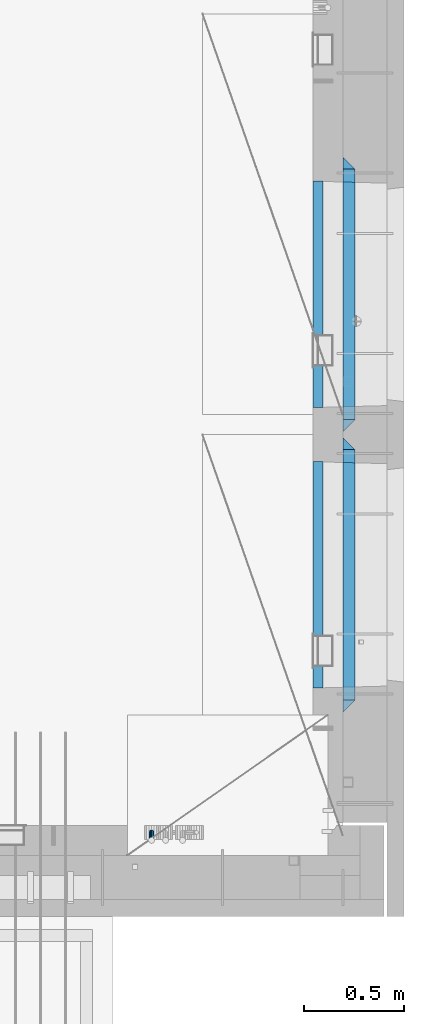
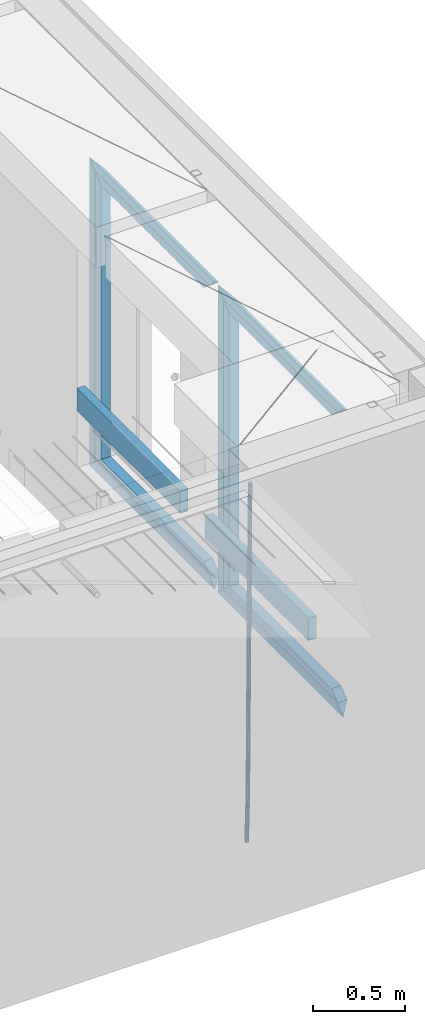
# One storey, part 124 of 334: 15 beams, 2 elements without a shape of their own.
"""IFC2X3 building model written with IfcOpenShell, lengths in millimetres."""

from ifc_helpers import new_model, si_unit, frame, origin_with_axes, place, context, subcontext, project, spatial, faceted_brep, material, type_object, element, aggregate, save


model = new_model("IFC2X3")

# Units and contexts
model_context = context("Model", 3, precision=1e-05, world=origin_with_axes())
body_context = subcontext(model_context, "Body", "Model", "MODEL_VIEW")
ifc_project = project(units=[si_unit("LENGTHUNIT", "METRE", prefix="MILLI"), si_unit("AREAUNIT", "SQUARE_METRE"), si_unit("VOLUMEUNIT", "CUBIC_METRE"), si_unit("MASSUNIT", "GRAM", prefix="KILO"), si_unit("TIMEUNIT", "SECOND"), si_unit("PLANEANGLEUNIT", "RADIAN"), si_unit("SOLIDANGLEUNIT", "STERADIAN"), si_unit("THERMODYNAMICTEMPERATUREUNIT", "DEGREE_CELSIUS"), si_unit("LUMINOUSINTENSITYUNIT", "LUMEN")], contexts=[model_context])

# Site, building, storey
site_placement = place(None, origin_with_axes())
site = spatial("IfcSite", under=ifc_project, at=site_placement, CompositionType="ELEMENT")
building_placement = place(site_placement, origin_with_axes())
building = spatial("IfcBuilding", under=site, at=building_placement, CompositionType="ELEMENT")
storey_placement = place(building_placement, origin_with_axes())
storey = spatial("IfcBuildingStorey", under=building, at=storey_placement, Name="3", CompositionType="ELEMENT", Elevation=0.0)

# Assembly, beam
assembly_1_placement = place(storey_placement, origin_with_axes())
assembly_1 = element("IfcElementAssembly", 1, at=assembly_1_placement, inside=storey, AssemblyPlace="NOTDEFINED", PredefinedType="REINFORCEMENT_UNIT")
ifc_material_1 = material()
beam_type_1 = type_object("IfcBeamType", Name="D25", PredefinedType="NOTDEFINED")
beam_1_placement = place(assembly_1_placement, frame((34104.9999999961, 7965.00000227913, 87990.0), z_axis=(0.00020576299992186, -0.999642804629538, -0.0267249099901004), x_axis=(-4.30000201928125e-08, -0.0267249099948059, 0.999642825806181)))
beam_1 = element("IfcBeam", 2, at=beam_1_placement, type_object=beam_type_1, material=ifc_material_1, Name="JM25", ObjectType="D25", context=body_context, shape_type="Brep", body=[
    faceted_brep([(-7.41420080885291e-08, -12.5, -3.63797880709171e-12), (-6.42030499875546e-08, -10.8253175473074, -6.25000000000364), (60.4103898235917, -10.8253175318459, -6.2499999938409), (60.4103898269532, -12.4999999845422, 6.16273609921336e-09), (-3.70782800018787e-08, -6.25000000000364, -10.8253175473074), (60.4103898202884, -6.24999998454587, -10.8253175411446), (-1.45519152283669e-11, -3.63797880709171e-12, -12.5), (60.4103898179019, 1.54577719513327e-08, -12.4999999938373), (3.70637280866504e-08, 6.25, -10.8253175473074), (60.410389817087, 6.25000001545777, -10.825317541141), (6.42030499875546e-08, 10.8253175473001, -6.25000000000364), (60.410389818062, 10.8253175627578, -6.24999999383726), (7.41420080885291e-08, 12.4999999999927, 0.0), (60.4103898205503, 12.5000000154541, 6.16273609921336e-09), (6.42176019027829e-08, 10.8253175473001, 6.24999999999636), (60.4103898238973, 10.8253175627651, 6.2500000061591), (3.70928319171071e-08, 6.24999999999636, 10.8253175473037), (60.4103898272151, 6.25000001546141, 10.8253175534664), (1.45519152283669e-11, -3.63797880709171e-12, 12.4999999999964), (60.4103898296162, 1.54541339725256e-08, 12.5000000061591), (-3.7049176171422e-08, -6.25000000000364, 10.8253175473001), (60.4103898304165, -6.24999998454587, 10.8253175534701), (-6.41884980723262e-08, -10.8253175473074, 6.25), (60.4103898294561, -10.8253175318459, 6.25000000616637), (61.0324985728803, -10.8253175316895, -6.24999999377542), (60.991802792938, -12.4999999843931, 6.22458173893392e-09), (61.0622854283865, -6.24999998437852, -10.8253175410755), (61.0731819955545, 1.5628756955266e-08, -12.4999999937718), (61.0622685480339, 6.25000001562512, -10.8253175410791), (61.032469335245, 10.8253175629216, -6.24999999377178), (60.9917690322181, 12.5000000156033, 6.22458173893392e-09), (60.9510732522613, 10.8253175629034, 6.25000000621731), (60.9212863967696, 6.25000001558874, 10.8253175535247), (60.9103898296162, 1.55814632307738e-08, 12.5000000062137), (60.9213032771368, -6.24999998441126, 10.8253175535174), (60.9511024898966, -10.8253175317113, 6.25000000621731), (61.6545545670233, -10.8253158516927, -6.24189838219536), (61.573166454793, -12.499998414296, 0.00757164385504439), (61.7141257553885, -6.24999822394238, -10.8168280205282), (61.7359179680789, 1.80548886419274e-06, -12.491368569139), (61.7140919992817, 6.25000177601396, -10.8168282403167), (61.6544960997562, 10.8253192428383, -6.2418987628771), (61.5730989426083, 12.5000015856094, 0.0075712042817031), (61.4917108303925, 10.8253190230062, 6.25704123032847), (61.4321396420273, 6.25000139525582, 10.8319708686649), (61.4103474293224, 1.36582457344048e-06, 12.5065114172721), (61.4321733981196, -6.24999860470052, 10.8319710884571), (61.4917692976451, -10.8253160715249, 6.25704161101385), (176.524302641745, -10.8250056210964, -4.74584321979273), (176.442914529529, -12.4996881836996, 1.50362680625403), (176.583873830095, -6.24968799334965, -9.3207728581292), (176.605666042786, 0.000312036081595579, -10.9953134067364), (176.583840074018, 6.25031200660669, -9.32077307791769), (176.524244174492, 10.8256294734347, -4.74584360047811), (176.44284701733, 12.5003118162058, 1.50362636668069), (176.361458905099, 10.8256292535989, 7.75309639272746), (176.301887716749, 6.25031162585219, 12.3280260310676), (176.280095504058, 0.000311596420942806, 14.0025665796711), (176.301921472827, -6.24968837410415, 12.3280262508561), (176.361517372367, -10.8250058409321, 7.75309677341284), (177.085397012124, -10.8250041057399, -4.73853556792164), (176.983633547483, -12.4996867233749, 1.51066909103247), (177.159881729676, -6.24968643771717, -9.31327097355097), (177.187129580227, 0.000313606451527448, -10.987740468332), (177.159839524218, 6.25031356221734, -9.31327130338468), (177.085323910098, 10.8256309887511, -4.73853613920801), (176.983549136537, 12.5003132764905, 1.51066843136869), (176.881785671867, 10.8256306588555, 7.7598730903228), (176.80730095433, 6.25031299082912, 12.3346084959521), (176.780053103794, 0.000312946667690994, 14.0090779907332), (176.807343159802, -6.2496870091054, 12.3346088257895), (176.881858773908, -10.8250044356355, 7.7598736616128), (177.646431799818, -10.8250018318176, -4.72756919822132), (177.524295146417, -12.4996845320202, 1.52123723245313), (177.735828462886, -6.24968410334986, -9.30201312475765), (177.768531371941, 0.00031596292683389, -10.9763759912421), (177.735777808921, 6.25031589654827, -9.30201361973741), (177.646344064575, 10.8256332626152, -4.72757005553649), (177.524193838486, 12.5003154677688, 1.52123624250817), (177.402057185071, 10.8256327675663, 7.77004267317898), (177.312660521988, 6.2503150390985, 12.3444865997226), (177.279957612933, 0.00031497282179771, 14.0188494661961), (177.312711175953, -6.24968496079964, 12.3444870946951), (177.402144920314, -10.8250023268702, 7.77004353049415), (299.377443161706, -10.8245084454466, -2.34813158632096), (299.255306508276, -12.4991911456491, 3.90067484435349), (299.466839824803, -6.24919071697514, -6.92257551286093), (299.499542733873, 0.0008093492979242, -8.59693837933446), (299.466789170867, 6.250809282923, -6.92257600783341), (299.377355426492, 10.8261266489935, -2.34813244364341), (299.255205200388, 12.5008088541435, 3.90067385440125), (299.133068546944, 10.826126153941, 10.1494802850757), (299.043671883861, 6.25080842546959, 14.7239242116229), (299.010968974762, 0.000808359200163977, 16.3982870780892), (299.043722537797, -6.24919157442127, 14.7239247065918), (299.133156282158, -10.8245089404954, 10.1494811423981), (299.98561436501, -10.8245059804758, -2.33624385599614), (299.97179243555, -12.4991882411778, 3.91467976726199), (299.995742293278, -6.24918857328521, -6.91223722345239), (299.999447243041, 0.000811375455668895, -8.58716690387519), (299.995736475976, 6.25081142679483, -6.91223684201032), (299.985604289133, 10.8261291142808, -2.33624319533556), (299.971750386685, 12.5008117588586, 3.91467993563856), (299.957928457196, 10.8261294971744, 10.1656035610831), (299.947800528913, 6.25081208998381, 14.7415969285394), (299.944095579151, 0.00081214124293183, 16.4165266089549), (299.947806346216, -6.24918791008895, 14.7415965471009), (299.957938533058, -10.8245055975785, 10.1656029004225), (300.593832239858, -10.8245078794353, -2.34543881707941), (300.688302931099, -12.4991904788549, 3.90384712594823), (300.524685350189, -6.24919022474205, -6.92023371784308), (300.499390115292, 0.000809814544481924, -8.59472497713432), (300.524724372954, 6.25080977519247, -6.92023401429469), (300.593899829313, 10.8261272150703, -2.34543933054374), (300.688380976673, 12.5008095210287, 3.90384653304136), (300.782851667915, 10.8261269216127, 10.1531324760799), (300.851998557599, 6.25080926691589, 14.7279273768363), (300.877293792495, 0.000809227632998955, 16.4024186361276), (300.851959534804, -6.24919073302226, 14.7279276732806), (300.782784078474, -10.8245081728965, 10.153132989537), (2293.32930409742, -10.8307295605009, -32.4713622331001), (2293.42377478865, -12.5054121599169, -26.2220762900724), (2293.26015720774, -6.2554119058077, -37.0461571338565), (2293.23486197284, -0.00541186651753378, -38.7206483931477), (2293.26019623051, 6.24458809413409, -37.0461574303008), (2293.32937168686, 10.8199055340046, -32.4713627465644), (2293.42385283421, 12.4945878399631, -26.2220768829684), (2293.51832352545, 10.8199052405434, -19.972790939948), (2293.58747041514, 6.24458758585388, -15.3979960391844), (2293.61276565003, -0.00541245343265473, -13.7235047798931), (2293.58743139236, -6.25541241408428, -15.3979957427327), (2293.51825593603, -10.8307298539585, -19.9727904264691), (2294.0420846676, -10.8307317859326, -32.4821379598216), (2294.03681932652, -12.5054140739521, -26.2313442200393), (2294.06778164886, -6.2554144273563, -37.0583666982457), (2294.10702478497, -0.00541458957013674, -38.7338336404937), (2294.14929890928, 6.24458531819619, -37.0595987724118), (2294.18327670435, 10.8199028679592, -32.4842719748667), (2294.1998538474, 12.4945854171456, -26.2338083683717), (2294.19458850632, 10.819903129126, -19.9830146285858), (2294.16889152506, 6.24458577054975, -15.4067858901581), (2294.12964838895, -0.0054140672327776, -13.7313189479173), (2294.08737426462, -6.2554139749991, -15.4055538159919), (2294.05339646956, -10.8307315247621, -19.9808806135297), (2294.75482297382, -10.84002603931, -32.4726521173216), (2294.64982751427, -12.513407826169, -26.2231856868602), (2294.87535820232, -6.26594539088183, -37.0476186524102), (2294.97913588268, -0.0167870967634371, -38.7222267036377), (2295.0383488692, 6.23299192477134, -37.0477663960555), (2295.03713108998, 10.8087684320271, -32.4729080168181), (2294.97580884799, 12.4844668051373, -26.2234811741473), (2294.87081338844, 10.8110850182784, -19.9740147436787), (2294.7502781599, 6.23700436985018, -15.3990482086047), (2294.64650047956, -0.0121539242718427, -13.7244401573698), (2294.58728749304, -6.26193294580662, -15.3989004649666), (2294.58850527227, -10.8377094530588, -19.9737588441894), (2316.44667268227, -11.1228921988077, -32.1839550346631), (2316.34167722271, -12.7962739856739, -25.9344886042054), (2316.56720791078, -6.54881155039038, -36.7589215697517), (2316.67098559113, -0.299653256264719, -38.4335296209792), (2316.73019857766, 5.95012576527006, -36.759069313397), (2316.72898079845, 10.5259022725259, -32.1842109341669), (2316.66765855643, 12.2016006456361, -25.9347840914961), (2316.56266309689, 10.5282188587698, -19.6853176610275), (2316.44212786836, 5.95413821035254, -15.1103511259389), (2316.33835018802, -0.295020083769487, -13.4357430747186), (2316.27913720149, -6.54479910530426, -15.1102033823008), (2316.28035498071, -11.1205756125637, -19.685061761531), (2317.13234804722, -11.1318335458927, -32.1748293731798), (2317.04181141085, -12.8054038787741, -25.9251705100723), (2317.2154741603, -6.5572650749491, -36.7502937866229), (2317.26891617525, -0.307450393454928, -38.4255717558117), (2317.27835434731, 5.94297770185585, -36.7517739018112), (2317.24125972588, 10.5192220504723, -32.1773930078925), (2317.16757178486, 12.1950816748285, -25.9281307404563), (2317.0770351485, 10.5215113419545, -19.6784718773561), (2316.99390903539, 5.94694287101083, -15.1030074639057), (2316.94046702047, -0.302871810494253, -13.4277294947169), (2316.9310288484, -6.55329990579412, -15.1015273487101), (2316.96812346982, -11.1295442544142, -19.6759082426288), (2317.81808136747, -11.1298054502913, -32.1659056455355), (2317.74200467508, -12.803315894289, -25.9160547315114), (2317.86379538118, -6.55536082026447, -36.7418676070083), (2317.8668976831, -0.305700748642266, -38.417815303761), (2317.82655701396, 5.94458339541234, -36.7446799039099), (2317.75358262347, 10.5207330230332, -32.1707766866384), (2317.66752794063, 12.1965725370646, -25.9216793252963), (2317.59145124823, 10.5230620930706, -19.6718284112721), (2317.54573723453, 5.94861746304377, -15.0958664497994), (2317.54263493262, -0.301042608574789, -13.4199187530394), (2317.58297560175, -6.55132675263303, -15.0930541529051), (2317.65594999224, -11.1274763802539, -19.6669573701693), (2417.81884292323, -10.831603083323, -30.8687911350135), (2417.74276623082, -12.505113527317, -24.618940220982), (2417.86455693691, -6.25715845329614, -35.4447530964935), (2417.86765923884, -0.00749838167394046, -37.1207007932499), (2417.82731856969, 6.24278576237703, -35.4475653933878), (2417.75434417921, 10.8189353900088, -30.8736621761236), (2417.66828949639, 12.494774904033, -24.6245648147851), (2417.59221280397, 10.8212644600353, -18.3747139007501), (2417.54649879028, 6.2468198300121, -13.79875193927), (2417.54339648837, -0.00284024161010166, -12.1228042425173), (2417.5837371575, -6.25312438566107, -13.795939642383), (2417.65671154798, -10.8292740132893, -18.3698428596399)], [[[0, 1, 2, 3]], [[1, 4, 5, 2]], [[4, 6, 7, 5]], [[6, 8, 9, 7]], [[8, 10, 11, 9]], [[10, 12, 13, 11]], [[12, 14, 15, 13]], [[14, 16, 17, 15]], [[16, 18, 19, 17]], [[18, 20, 21, 19]], [[20, 22, 23, 21]], [[22, 0, 3, 23]], [[22, 20, 18, 16, 14, 12, 10, 8, 6, 4, 1, 0]], [[3, 2, 24, 25]], [[2, 5, 26, 24]], [[5, 7, 27, 26]], [[7, 9, 28, 27]], [[9, 11, 29, 28]], [[11, 13, 30, 29]], [[13, 15, 31, 30]], [[15, 17, 32, 31]], [[17, 19, 33, 32]], [[19, 21, 34, 33]], [[21, 23, 35, 34]], [[23, 3, 25, 35]], [[25, 24, 36, 37]], [[24, 26, 38, 36]], [[26, 27, 39, 38]], [[27, 28, 40, 39]], [[28, 29, 41, 40]], [[29, 30, 42, 41]], [[30, 31, 43, 42]], [[31, 32, 44, 43]], [[32, 33, 45, 44]], [[33, 34, 46, 45]], [[34, 35, 47, 46]], [[35, 25, 37, 47]], [[37, 36, 48, 49]], [[36, 38, 50, 48]], [[38, 39, 51, 50]], [[39, 40, 52, 51]], [[40, 41, 53, 52]], [[41, 42, 54, 53]], [[42, 43, 55, 54]], [[43, 44, 56, 55]], [[44, 45, 57, 56]], [[45, 46, 58, 57]], [[46, 47, 59, 58]], [[47, 37, 49, 59]], [[49, 48, 60, 61]], [[48, 50, 62, 60]], [[50, 51, 63, 62]], [[51, 52, 64, 63]], [[52, 53, 65, 64]], [[53, 54, 66, 65]], [[54, 55, 67, 66]], [[55, 56, 68, 67]], [[56, 57, 69, 68]], [[57, 58, 70, 69]], [[58, 59, 71, 70]], [[59, 49, 61, 71]], [[61, 60, 72, 73]], [[60, 62, 74, 72]], [[62, 63, 75, 74]], [[63, 64, 76, 75]], [[64, 65, 77, 76]], [[65, 66, 78, 77]], [[66, 67, 79, 78]], [[67, 68, 80, 79]], [[68, 69, 81, 80]], [[69, 70, 82, 81]], [[70, 71, 83, 82]], [[71, 61, 73, 83]], [[73, 72, 84, 85]], [[72, 74, 86, 84]], [[74, 75, 87, 86]], [[75, 76, 88, 87]], [[76, 77, 89, 88]], [[77, 78, 90, 89]], [[78, 79, 91, 90]], [[79, 80, 92, 91]], [[80, 81, 93, 92]], [[81, 82, 94, 93]], [[82, 83, 95, 94]], [[83, 73, 85, 95]], [[85, 84, 96, 97]], [[84, 86, 98, 96]], [[86, 87, 99, 98]], [[87, 88, 100, 99]], [[88, 89, 101, 100]], [[89, 90, 102, 101]], [[90, 91, 103, 102]], [[91, 92, 104, 103]], [[92, 93, 105, 104]], [[93, 94, 106, 105]], [[94, 95, 107, 106]], [[95, 85, 97, 107]], [[97, 96, 108, 109]], [[96, 98, 110, 108]], [[98, 99, 111, 110]], [[99, 100, 112, 111]], [[100, 101, 113, 112]], [[101, 102, 114, 113]], [[102, 103, 115, 114]], [[103, 104, 116, 115]], [[104, 105, 117, 116]], [[105, 106, 118, 117]], [[106, 107, 119, 118]], [[107, 97, 109, 119]], [[109, 108, 120, 121]], [[108, 110, 122, 120]], [[110, 111, 123, 122]], [[111, 112, 124, 123]], [[112, 113, 125, 124]], [[113, 114, 126, 125]], [[114, 115, 127, 126]], [[115, 116, 128, 127]], [[116, 117, 129, 128]], [[117, 118, 130, 129]], [[118, 119, 131, 130]], [[119, 109, 121, 131]], [[121, 120, 132, 133]], [[120, 122, 134, 132]], [[122, 123, 135, 134]], [[123, 124, 136, 135]], [[124, 125, 137, 136]], [[125, 126, 138, 137]], [[126, 127, 139, 138]], [[127, 128, 140, 139]], [[128, 129, 141, 140]], [[129, 130, 142, 141]], [[130, 131, 143, 142]], [[131, 121, 133, 143]], [[133, 132, 144, 145]], [[132, 134, 146, 144]], [[134, 135, 147, 146]], [[135, 136, 148, 147]], [[136, 137, 149, 148]], [[137, 138, 150, 149]], [[138, 139, 151, 150]], [[139, 140, 152, 151]], [[140, 141, 153, 152]], [[141, 142, 154, 153]], [[142, 143, 155, 154]], [[143, 133, 145, 155]], [[145, 144, 156, 157]], [[144, 146, 158, 156]], [[146, 147, 159, 158]], [[147, 148, 160, 159]], [[148, 149, 161, 160]], [[149, 150, 162, 161]], [[150, 151, 163, 162]], [[151, 152, 164, 163]], [[152, 153, 165, 164]], [[153, 154, 166, 165]], [[154, 155, 167, 166]], [[155, 145, 157, 167]], [[157, 156, 168, 169]], [[156, 158, 170, 168]], [[158, 159, 171, 170]], [[159, 160, 172, 171]], [[160, 161, 173, 172]], [[161, 162, 174, 173]], [[162, 163, 175, 174]], [[163, 164, 176, 175]], [[164, 165, 177, 176]], [[165, 166, 178, 177]], [[166, 167, 179, 178]], [[167, 157, 169, 179]], [[169, 168, 180, 181]], [[168, 170, 182, 180]], [[170, 171, 183, 182]], [[171, 172, 184, 183]], [[172, 173, 185, 184]], [[173, 174, 186, 185]], [[174, 175, 187, 186]], [[175, 176, 188, 187]], [[176, 177, 189, 188]], [[177, 178, 190, 189]], [[178, 179, 191, 190]], [[179, 169, 181, 191]], [[181, 180, 192, 193]], [[180, 182, 194, 192]], [[182, 183, 195, 194]], [[183, 184, 196, 195]], [[184, 185, 197, 196]], [[185, 186, 198, 197]], [[186, 187, 199, 198]], [[187, 188, 200, 199]], [[188, 189, 201, 200]], [[189, 190, 202, 201]], [[190, 191, 203, 202]], [[191, 181, 193, 203]], [[194, 195, 196, 197, 198, 199, 200, 201, 202, 203, 193, 192]]]),
])
aggregate(assembly_1, [beam_1])

# Assembly, beams
assembly_2_placement = place(storey_placement, origin_with_axes())
assembly_2 = element("IfcElementAssembly", 3, at=assembly_2_placement, inside=storey, AssemblyPlace="NOTDEFINED", PredefinedType="REINFORCEMENT_UNIT")
ifc_material_2 = material(Name="TIMBER/T24")
beam_type_2 = type_object("IfcBeamType", PredefinedType="NOTDEFINED")
beam_2_placement = place(assembly_2_placement, frame((34935.0002758707, 8685.00118845241, 88685.0), z_axis=(0.0, 0.0, 1.0), x_axis=(0.0, 1.0, 0.0)))
beam_2 = element("IfcBeam", 4, at=beam_2_placement, type_object=beam_type_2, material=ifc_material_2, context=body_context, shape_type="Brep", body=[
    faceted_brep([(-3.63797880709171e-12, 24.9999999999964, -75.0), (-3.63797880709171e-12, 24.9999999999964, 75.0), (1130.0, 25.0, 75.0), (1130.0, 25.0, -75.0), (0.0, -25.0000000000073, 75.0), (1130.0, -25.0, 75.0), (0.0, -25.0000000000073, -75.0), (1130.0, -25.0, -75.0)], [[[0, 1, 2, 3]], [[1, 4, 5, 2]], [[4, 6, 7, 5]], [[6, 0, 3, 7]], [[5, 7, 3, 2]], [[6, 4, 1, 0]]]),
])
beam_3_placement = place(assembly_2_placement, frame((34935.0002758707, 10085.0011884524, 88685.0), z_axis=(0.0, 0.0, 1.0), x_axis=(0.0, 1.0, 0.0)))
beam_3 = element("IfcBeam", 5, at=beam_3_placement, type_object=beam_type_2, material=ifc_material_2, context=body_context, shape_type="Brep", body=[
    faceted_brep([(-3.63797880709171e-12, 24.9999999999964, -75.0), (-3.63797880709171e-12, 24.9999999999964, 75.0), (1130.0, 25.0, 75.0), (1130.0, 25.0, -75.0), (0.0, -25.0000000000073, 75.0), (1130.0, -25.0, 75.0), (0.0, -25.0000000000073, -75.0), (1130.0, -25.0, -75.0)], [[[0, 1, 2, 3]], [[1, 4, 5, 2]], [[4, 6, 7, 5]], [[6, 0, 3, 7]], [[5, 7, 3, 2]], [[6, 4, 1, 0]]]),
])
ifc_material_3 = material(Name="CONCRETE/C25/30")
beam_type_3 = type_object("IfcBeamType", PredefinedType="NOTDEFINED")
beam_4_placement = place(assembly_2_placement, frame((35090.0, 8565.0001381367, 90145.0), z_axis=(0.0, 0.0, -1.0), x_axis=(0.0, 1.0, 0.0)))
beam_4 = element("IfcBeam", 6, at=beam_4_placement, type_object=beam_type_3, material=ifc_material_3, Name="SK", context=body_context, shape_type="Brep", body=[
    faceted_brep([(60.0000000000073, 30.0, 30.0), (0.0, -30.0, -30.0), (60.0000000000073, -30.0, 30.0), (1309.99990463256, 30.0, 30.0), (1369.99990463257, -30.0, -30.0), (1309.99990463256, -30.0, 30.0)], [[[0, 1, 2]], [[1, 0, 3, 4]], [[2, 1, 4, 5]], [[0, 2, 5, 3]], [[4, 3, 5]]]),
])
beam_5_placement = place(assembly_2_placement, frame((35090.0, 8625.0001381367, 90085.0), z_axis=(0.0, 0.0, -1.0), x_axis=(0.0, 1.0, 0.0)))
beam_5 = element("IfcBeam", 7, at=beam_5_placement, type_object=beam_type_3, material=ifc_material_3, Name="SK", context=body_context, shape_type="Brep", body=[
    faceted_brep([(65.6755803082433, 30.0, 25.6756756756804), (64.0539586866216, -30.0, 24.0540540540533), (1185.94585057852, -30.0, 24.0540540540533), (1184.32422895689, 30.0, 25.6756756756804), (65.6755803082433, 30.0, 26.2933545375708), (64.0539586866216, -30.0, 24.9033931479062), (0.0, -30.0, -30.0), (0.0, 30.0, -30.0), (1249.99990463257, 30.0, -30.0), (1249.99990463257, -30.0, -30.0), (1185.94585057852, -30.0, 24.9034748914273), (1184.32422895689, 30.0, 26.293436281092)], [[[0, 1, 2, 3]], [[1, 0, 4, 5]], [[6, 5, 4, 7]], [[6, 7, 8, 9]], [[2, 1, 5, 6, 9, 10]], [[3, 2, 10, 11]], [[7, 4, 0, 3, 11, 8]], [[10, 9, 8, 11]]]),
])
beam_6_placement = place(assembly_2_placement, frame((35090.0, 9905.00004276927, 90175.0), z_axis=(0.0, -1.0, 0.0), x_axis=(0.0, 0.0, -1.0)))
beam_6 = element("IfcBeam", 8, at=beam_6_placement, type_object=beam_type_3, material=ifc_material_3, Name="SK", context=body_context, shape_type="Brep", body=[
    faceted_brep([(60.0000000000073, 30.0, 30.0), (0.0, -30.0, -30.0), (60.0000000000073, -30.0, 30.0), (1995.0, 30.0, 30.0), (2055.0, -30.0, -30.0), (1995.0, -30.0, 30.0)], [[[0, 1, 2]], [[3, 4, 1, 0]], [[4, 5, 2, 1]], [[5, 3, 0, 2]], [[5, 4, 3]]]),
])
beam_7_placement = place(assembly_2_placement, frame((35090.0, 9875.00004276927, 88210.0), z_axis=(0.0, 0.0, 1.0), x_axis=(0.0, -1.0, 0.0)))
beam_7 = element("IfcBeam", 9, at=beam_7_placement, type_object=beam_type_3, material=ifc_material_3, Name="SK", context=body_context, shape_type="Brep", body=[
    faceted_brep([(1185.94594588314, -29.9999988381387, 24.0540541168593), (1184.32432432432, 29.9999988381387, 25.6756756756804), (65.6756756756768, 30.0, 25.6756756756804), (64.0540540540533, -30.0, 24.0540540540533), (1185.94594594595, -30.0, 24.9033931479207), (1184.32432432433, 30.0, 26.2933545375854), (1249.99990463257, -30.0, -30.0), (1249.99990463257, 30.0, -30.0), (0.0, 30.0, -30.0), (65.6756756756768, 30.0, 26.293436281092), (64.0540540540533, -30.0, 24.9034748914419), (0.0, -30.0, -30.0)], [[[0, 1, 2, 3]], [[1, 0, 4, 5]], [[6, 7, 5, 4]], [[2, 1, 5, 7, 8, 9]], [[3, 2, 9, 10]], [[6, 4, 0, 3, 10, 11]], [[11, 8, 7, 6]], [[11, 10, 9, 8]]]),
])
beam_8_placement = place(assembly_2_placement, frame((35090.0, 9935.00004276927, 88150.0), z_axis=(0.0, 0.0, 1.0), x_axis=(0.0, -1.0, 0.0)))
beam_8 = element("IfcBeam", 10, at=beam_8_placement, type_object=beam_type_3, material=ifc_material_3, Name="SK", context=body_context, shape_type="Brep", body=[
    faceted_brep([(1369.99990463257, -30.0, -30.0), (1309.99990463256, 30.0, 30.0), (1309.99990463256, -30.0, 30.0), (60.0000000000073, 30.0, 30.0), (60.0000000000073, -30.0, 30.0), (0.0, -30.0, -30.0)], [[[0, 1, 2]], [[3, 4, 2, 1]], [[4, 5, 0, 2]], [[5, 3, 1, 0]], [[3, 5, 4]]]),
])
beam_9_placement = place(assembly_2_placement, frame((35090.0, 9965.00023350414, 90145.0), z_axis=(0.0, 0.0, -1.0), x_axis=(0.0, 1.0, 0.0)))
beam_9 = element("IfcBeam", 11, at=beam_9_placement, type_object=beam_type_3, material=ifc_material_3, Name="SK", context=body_context, shape_type="Brep", body=[
    faceted_brep([(60.0000000000073, 30.0, 30.0), (0.0, -30.0, -30.0), (60.0000000000073, -30.0, 30.0), (1309.99942779541, 30.0, 30.0), (1369.99942779541, -30.0, -30.0), (1309.99942779541, -30.0, 30.0)], [[[0, 1, 2]], [[1, 0, 3, 4]], [[2, 1, 4, 5]], [[0, 2, 5, 3]], [[4, 3, 5]]]),
])
beam_10_placement = place(assembly_2_placement, frame((35090.0, 10025.0002335041, 90085.0), z_axis=(0.0, 0.0, -1.0), x_axis=(0.0, 1.0, 0.0)))
beam_10 = element("IfcBeam", 12, at=beam_10_placement, type_object=beam_type_3, material=ifc_material_3, Name="SK", context=body_context, shape_type="Brep", body=[
    faceted_brep([(65.6751034710851, 30.0, 25.6756756756804), (64.0534818494634, -30.0, 24.0540540540533), (1185.94537374136, -30.0, 24.0540540540533), (1184.32375211974, 30.0, 25.6756756756804), (65.6751034710851, 30.0, 26.2929458199942), (64.0534818494634, -30.0, 24.9029844303586), (0.0, -30.0, -30.0), (0.0, 30.0, -30.0), (1249.99942779541, 30.0, -30.0), (1249.99942779541, -30.0, -30.0), (1185.94537374136, -30.0, 24.9034748914273), (1184.32375211974, 30.0, 26.293436281092)], [[[0, 1, 2, 3]], [[1, 0, 4, 5]], [[6, 5, 4, 7]], [[6, 7, 8, 9]], [[2, 1, 5, 6, 9, 10]], [[3, 2, 10, 11]], [[7, 4, 0, 3, 11, 8]], [[10, 9, 8, 11]]]),
])
beam_11_placement = place(assembly_2_placement, frame((35090.0, 11304.9996612995, 90175.0), z_axis=(0.0, -1.0, 0.0), x_axis=(0.0, 0.0, -1.0)))
beam_11 = element("IfcBeam", 13, at=beam_11_placement, type_object=beam_type_3, material=ifc_material_3, Name="SK", context=body_context, shape_type="Brep", body=[
    faceted_brep([(60.0000000000073, 30.0, 30.0), (0.0, -30.0, -30.0), (60.0000000000073, -30.0, 30.0), (1995.0, 30.0, 30.0), (2055.0, -30.0, -30.0), (1995.0, -30.0, 30.0)], [[[0, 1, 2]], [[3, 4, 1, 0]], [[4, 5, 2, 1]], [[5, 3, 0, 2]], [[5, 4, 3]]]),
])
beam_12_placement = place(assembly_2_placement, frame((35090.0, 11274.9996612995, 88210.0), z_axis=(0.0, 0.0, 1.0), x_axis=(0.0, -1.0, 0.0)))
beam_12 = element("IfcBeam", 14, at=beam_12_placement, type_object=beam_type_3, material=ifc_material_3, Name="SK", context=body_context, shape_type="Brep", body=[
    faceted_brep([(1185.94594588314, -29.9999988381387, 24.0540541168593), (1184.32432432432, 29.9999988381387, 25.6756756756804), (65.6756756756768, 30.0, 25.6756756756804), (64.0540540540533, -30.0, 24.0540540540533), (1185.94594594595, -30.0, 24.9029844303586), (1184.32432432433, 30.0, 26.2929458200088), (1249.99942779541, -30.0, -30.0), (1249.99942779541, 30.0, -30.0), (0.0, 30.0, -30.0), (65.6756756756768, 30.0, 26.293436281092), (64.0540540540533, -30.0, 24.9034748914419), (0.0, -30.0, -30.0)], [[[0, 1, 2, 3]], [[1, 0, 4, 5]], [[6, 7, 5, 4]], [[2, 1, 5, 7, 8, 9]], [[3, 2, 9, 10]], [[6, 4, 0, 3, 10, 11]], [[11, 8, 7, 6]], [[11, 10, 9, 8]]]),
])
beam_13_placement = place(assembly_2_placement, frame((35090.0, 11334.9996612995, 88150.0), z_axis=(0.0, 0.0, 1.0), x_axis=(0.0, -1.0, 0.0)))
beam_13 = element("IfcBeam", 15, at=beam_13_placement, type_object=beam_type_3, material=ifc_material_3, Name="SK", context=body_context, shape_type="Brep", body=[
    faceted_brep([(1369.99942779541, -30.0, -30.0), (1309.99942779541, 30.0, 30.0), (1309.99942779541, -30.0, 30.0), (60.0000000000073, 30.0, 30.0), (60.0000000000073, -30.0, 30.0), (0.0, -30.0, -30.0)], [[[0, 1, 2]], [[3, 4, 2, 1]], [[4, 5, 0, 2]], [[5, 3, 1, 0]], [[3, 5, 4]]]),
])
beam_type_4 = type_object("IfcBeamType", PredefinedType="NOTDEFINED")
beam_14_placement = place(assembly_2_placement, frame((35090.0, 9840.00004276927, 90115.0), z_axis=(0.0, -1.0, 0.0), x_axis=(0.0, 0.0, -1.0)))
beam_14 = element("IfcBeam", 16, at=beam_14_placement, type_object=beam_type_4, material=ifc_material_3, Name="SK", context=body_context, shape_type="Brep", body=[
    faceted_brep([(0.0, -30.0, -35.0), (54.9034748914273, -30.0, 29.0540540540533), (56.2934362811066, 30.0, 30.6756756756768), (0.0, 30.0, -35.0), (1935.0, 30.0, -35.0), (1935.0, -30.0, -35.0), (1880.09652510857, -30.0, 29.0540540540533), (1878.70656371891, 30.0, 30.6756756756749)], [[[0, 1, 2, 3]], [[4, 5, 0, 3]], [[1, 0, 5, 6]], [[2, 1, 6, 7]], [[3, 2, 7, 4]], [[6, 5, 4, 7]]]),
])
beam_15_placement = place(assembly_2_placement, frame((35090.0, 11239.9996612995, 90115.0), z_axis=(0.0, -1.0, 0.0), x_axis=(0.0, 0.0, -1.0)))
beam_15 = element("IfcBeam", 17, at=beam_15_placement, type_object=beam_type_4, material=ifc_material_3, Name="SK", context=body_context, shape_type="Brep", body=[
    faceted_brep([(0.0, -30.0, -35.0), (54.9034748914273, -30.0, 29.0540540540533), (56.2934362811066, 30.0, 30.6756756756768), (0.0, 30.0, -35.0), (1935.0, 30.0, -35.0), (1935.0, -30.0, -35.0), (1880.09652510857, -30.0, 29.0540540540533), (1878.70656371891, 30.0, 30.6756756756749)], [[[0, 1, 2, 3]], [[4, 5, 0, 3]], [[1, 0, 5, 6]], [[2, 1, 6, 7]], [[3, 2, 7, 4]], [[6, 5, 4, 7]]]),
])
aggregate(assembly_2, [beam_2, beam_3, beam_4, beam_5, beam_6, beam_14, beam_7, beam_8, beam_9, beam_10, beam_11, beam_15, beam_12, beam_13])

save(model, "model.ifc")
